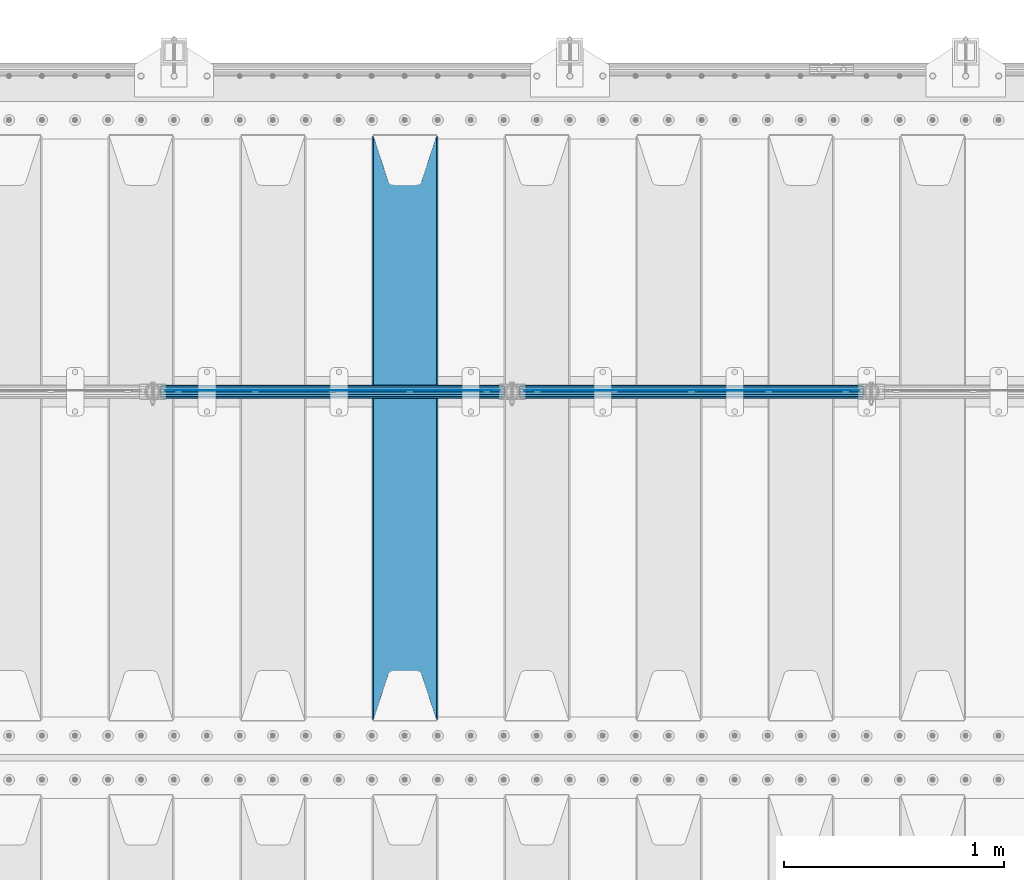
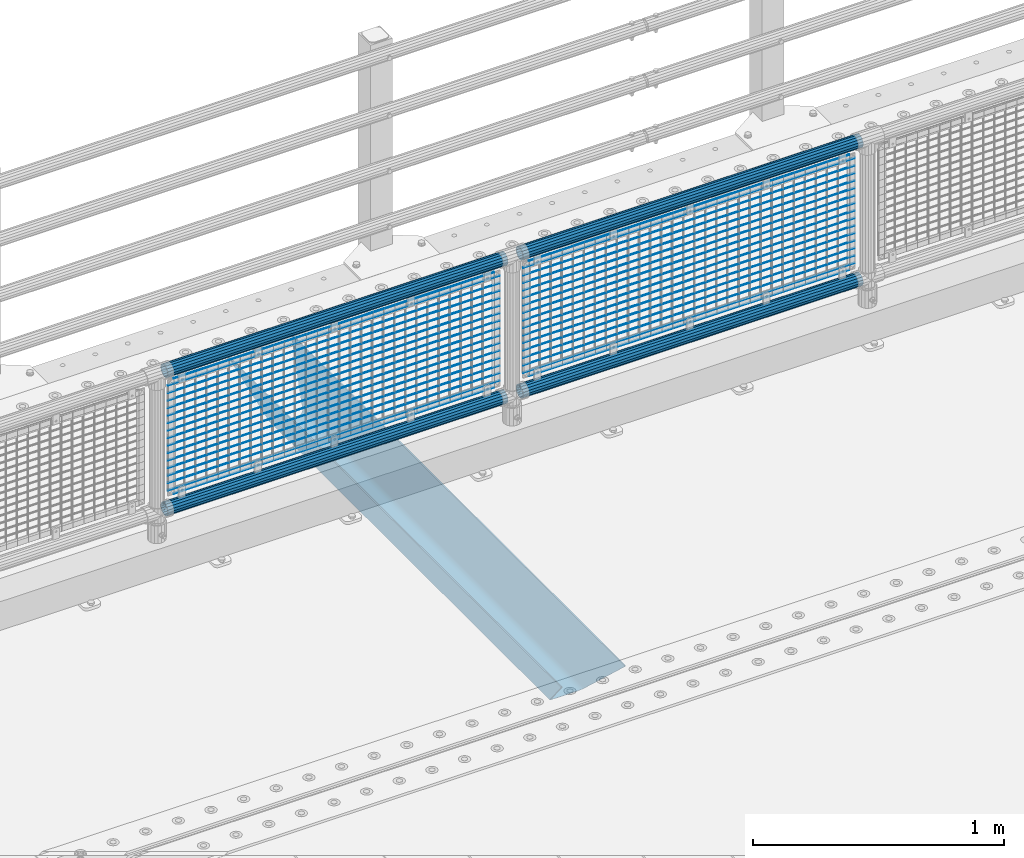
# One storey, part 115 of 242: 39 beams.
"""IFC2X3 building model written with IfcOpenShell, lengths in millimetres."""

from ifc_helpers import new_model, si_unit, frame, origin_with_axes, place, context, subcontext, project, spatial, faceted_brep, material, type_object, element, save


model = new_model("IFC2X3")

# Units and contexts
model_context = context("Model", 3, precision=1e-05, world=origin_with_axes())
body_context = subcontext(model_context, "Body", "Model", "MODEL_VIEW")
ifc_project = project(units=[si_unit("LENGTHUNIT", "METRE", prefix="MILLI"), si_unit("AREAUNIT", "SQUARE_METRE"), si_unit("VOLUMEUNIT", "CUBIC_METRE"), si_unit("MASSUNIT", "GRAM", prefix="KILO"), si_unit("TIMEUNIT", "SECOND"), si_unit("PLANEANGLEUNIT", "RADIAN"), si_unit("SOLIDANGLEUNIT", "STERADIAN"), si_unit("THERMODYNAMICTEMPERATUREUNIT", "DEGREE_CELSIUS"), si_unit("LUMINOUSINTENSITYUNIT", "LUMEN")], contexts=[model_context])

# Site, building, storey
site_placement = place(None, origin_with_axes())
site = spatial("IfcSite", under=ifc_project, at=site_placement, CompositionType="ELEMENT")
building_placement = place(site_placement, origin_with_axes())
building = spatial("IfcBuilding", under=site, at=building_placement, Name="Standard", CompositionType="ELEMENT")
storey_placement = place(building_placement, origin_with_axes())
storey = spatial("IfcBuildingStorey", under=building, at=storey_placement, Name="Undefined", CompositionType="ELEMENT", Elevation=0.0)

# Beams
ifc_material_1 = material(Name="Misc_Undefined")
beam_type_1 = type_object("IfcBeamType", Name="D3", PredefinedType="NOTDEFINED")
for number, where, z_axis, x_axis in (
    (1, (-38508.0, -19329.5, 851.596999999999), (0.0, 0.0, 1.0), (1.0, 0.0, 0.0)),
    (2, (-38508.0, -19329.5, 669.452), (0.0, 0.0, 1.0), (1.0, 0.0, 0.0)),
    (3, (-38508.0, -19329.5, 523.736), (0.0, 0.0, 1.0), (1.0, 0.0, 0.0)),
    (4, (-38508.0, -19329.5, 487.307), (0.0, 0.0, 1.0), (1.0, 0.0, 0.0)),
    (5, (-38508.0, -19329.5, 705.881), (0.0, 0.0, 1.0), (1.0, 0.0, 0.0)),
    (6, (-38508.0, -19329.5, 596.594), (0.0, 0.0, 1.0), (1.0, 0.0, 0.0)),
    (7, (-38508.0, -19329.5, 450.878), (0.0, 0.0, 1.0), (1.0, 0.0, 0.0)),
    (8, (-38508.0, -19329.5, 815.167999999999), (0.0, 0.0, 1.0), (1.0, 0.0, 0.0)),
    (9, (-38508.0, -19329.5, 888.025999999999), (0.0, 0.0, 1.0), (1.0, 0.0, 0.0)),
    (10, (-38508.0, -19329.5, 778.738999999999), (0.0, 0.0, 1.0), (1.0, 0.0, 0.0)),
    (11, (-38508.0, -19329.5, 742.309999999999), (0.0, 0.0, 1.0), (1.0, 0.0, 0.0)),
    (12, (-38508.0, -19329.5, 633.023), (0.0, 0.0, 1.0), (1.0, 0.0, 0.0)),
    (13, (-38508.0, -19329.5, 560.165), (0.0, 0.0, 1.0), (1.0, 0.0, 0.0)),
    (14, (-38508.0, -19329.5, 414.449), (0.0, 0.0, 1.0), (1.0, 0.0, 0.0)),
):
    element("IfcBeam", number, at=place(storey_placement, frame(where, z_axis=z_axis, x_axis=x_axis)), inside=storey, type_object=beam_type_1, material=ifc_material_1, ObjectType="D3", context=body_context, shape_type="Brep", body=[
        faceted_brep([(0.0, -1.50000000000364, 0.0), (-3.63797880709171e-12, -0.750000000003638, -1.29903810567669), (1523.0, -0.75, -1.29903810567669), (1523.0, -1.5, 0.0), (0.0, 0.749999999996362, -1.29903810567669), (1523.0, 0.75, -1.29903810567669), (-3.63797880709171e-12, 1.49999999999636, 0.0), (1523.0, 1.5, 0.0), (0.0, 0.749999999996362, 1.29903810567669), (1523.0, 0.75, 1.29903810567669), (-3.63797880709171e-12, -0.750000000003638, 1.29903810567669), (1523.0, -0.75, 1.29903810567669)], [[[0, 1, 2, 3]], [[1, 4, 5, 2]], [[4, 6, 7, 5]], [[6, 8, 9, 7]], [[8, 10, 11, 9]], [[10, 0, 3, 11]], [[5, 7, 9, 11, 3, 2]], [[10, 8, 6, 4, 1, 0]]]),
    ])
beam_1_placement = place(storey_placement, frame((-38483.0, -19329.5, 353.02), z_axis=(0.0, 0.0, 1.0), x_axis=(1.0, 0.0, 0.0)))
element("IfcBeam", 15, at=beam_1_placement, inside=storey, type_object=beam_type_1, material=ifc_material_1, ObjectType="D3", context=body_context, shape_type="Brep", body=[
    faceted_brep([(0.0, -1.50000000000364, 0.0), (-3.63797880709171e-12, -0.750000000003638, -1.29903810567669), (1473.0, -0.75, -1.29903810567669), (1473.0, -1.5, 0.0), (0.0, 0.749999999996362, -1.29903810567669), (1473.0, 0.75, -1.29903810567663), (-3.63797880709171e-12, 1.49999999999636, 0.0), (1473.0, 1.5, 0.0), (0.0, 0.749999999996362, 1.29903810567669), (1473.0, 0.75, 1.29903810567669), (-3.63797880709171e-12, -0.750000000003638, 1.29903810567669), (1473.0, -0.75, 1.29903810567669)], [[[0, 1, 2, 3]], [[1, 4, 5, 2]], [[4, 6, 7, 5]], [[6, 8, 9, 7]], [[8, 10, 11, 9]], [[10, 0, 3, 11]], [[5, 7, 9, 11, 3, 2]], [[10, 8, 6, 4, 1, 0]]]),
])
beam_2_placement = place(storey_placement, frame((-38508.0, -19329.5, 378.02), z_axis=(0.0, 0.0, 1.0), x_axis=(1.0, 0.0, 0.0)))
element("IfcBeam", 16, at=beam_2_placement, inside=storey, type_object=beam_type_1, material=ifc_material_1, ObjectType="D3", context=body_context, shape_type="Brep", body=[
    faceted_brep([(0.0, -1.50000000000364, 0.0), (-3.63797880709171e-12, -0.750000000003638, -1.29903810567669), (1523.0, -0.75, -1.29903810567669), (1523.0, -1.5, 0.0), (0.0, 0.749999999996362, -1.29903810567669), (1523.0, 0.75, -1.29903810567669), (-3.63797880709171e-12, 1.49999999999636, 0.0), (1523.0, 1.5, 0.0), (0.0, 0.749999999996362, 1.29903810567669), (1523.0, 0.75, 1.29903810567669), (-3.63797880709171e-12, -0.750000000003638, 1.29903810567669), (1523.0, -0.75, 1.29903810567669)], [[[0, 1, 2, 3]], [[1, 4, 5, 2]], [[4, 6, 7, 5]], [[6, 8, 9, 7]], [[8, 10, 11, 9]], [[10, 0, 3, 11]], [[5, 7, 9, 11, 3, 2]], [[10, 8, 6, 4, 1, 0]]]),
])
beam_3_placement = place(storey_placement, frame((-38483.0, -19329.5, 913.02), z_axis=(0.0, 0.0, 1.0), x_axis=(1.0, 0.0, 0.0)))
element("IfcBeam", 17, at=beam_3_placement, inside=storey, type_object=beam_type_1, material=ifc_material_1, ObjectType="D3", context=body_context, shape_type="Brep", body=[
    faceted_brep([(0.0, -1.50000000000364, 0.0), (-3.63797880709171e-12, -0.750000000003638, -1.29903810567669), (1473.0, -0.75, -1.29903810567669), (1473.0, -1.5, 0.0), (0.0, 0.749999999996362, -1.29903810567669), (1473.0, 0.75, -1.29903810567663), (-3.63797880709171e-12, 1.49999999999636, 0.0), (1473.0, 1.5, 0.0), (0.0, 0.749999999996362, 1.29903810567669), (1473.0, 0.75, 1.29903810567669), (-3.63797880709171e-12, -0.750000000003638, 1.29903810567669), (1473.0, -0.75, 1.29903810567669)], [[[0, 1, 2, 3]], [[1, 4, 5, 2]], [[4, 6, 7, 5]], [[6, 8, 9, 7]], [[8, 10, 11, 9]], [[10, 0, 3, 11]], [[5, 7, 9, 11, 3, 2]], [[10, 8, 6, 4, 1, 0]]]),
])
for number, where, z_axis, x_axis in (
    (18, (-40141.0, -19329.5, 851.596999999999), (0.0, 0.0, 1.0), (1.0, 0.0, 0.0)),
    (19, (-40141.0, -19329.5, 669.452), (0.0, 0.0, 1.0), (1.0, 0.0, 0.0)),
    (20, (-40141.0, -19329.5, 523.736), (0.0, 0.0, 1.0), (1.0, 0.0, 0.0)),
    (21, (-40141.0, -19329.5, 487.307), (0.0, 0.0, 1.0), (1.0, 0.0, 0.0)),
    (22, (-40141.0, -19329.5, 705.881), (0.0, 0.0, 1.0), (1.0, 0.0, 0.0)),
    (23, (-40141.0, -19329.5, 596.594), (0.0, 0.0, 1.0), (1.0, 0.0, 0.0)),
    (24, (-40141.0, -19329.5, 450.878), (0.0, 0.0, 1.0), (1.0, 0.0, 0.0)),
    (25, (-40141.0, -19329.5, 815.167999999999), (0.0, 0.0, 1.0), (1.0, 0.0, 0.0)),
    (26, (-40141.0, -19329.5, 888.025999999999), (0.0, 0.0, 1.0), (1.0, 0.0, 0.0)),
    (27, (-40141.0, -19329.5, 778.738999999999), (0.0, 0.0, 1.0), (1.0, 0.0, 0.0)),
    (28, (-40141.0, -19329.5, 742.309999999999), (0.0, 0.0, 1.0), (1.0, 0.0, 0.0)),
    (29, (-40141.0, -19329.5, 633.023), (0.0, 0.0, 1.0), (1.0, 0.0, 0.0)),
    (30, (-40141.0, -19329.5, 560.165), (0.0, 0.0, 1.0), (1.0, 0.0, 0.0)),
    (31, (-40141.0, -19329.5, 414.449), (0.0, 0.0, 1.0), (1.0, 0.0, 0.0)),
):
    element("IfcBeam", number, at=place(storey_placement, frame(where, z_axis=z_axis, x_axis=x_axis)), inside=storey, type_object=beam_type_1, material=ifc_material_1, ObjectType="D3", context=body_context, shape_type="Brep", body=[
        faceted_brep([(0.0, -1.50000000000364, 0.0), (-3.63797880709171e-12, -0.750000000003638, -1.29903810567669), (1523.0, -0.75, -1.29903810567669), (1523.0, -1.5, 0.0), (0.0, 0.749999999996362, -1.29903810567669), (1523.0, 0.75, -1.29903810567669), (-3.63797880709171e-12, 1.49999999999636, 0.0), (1523.0, 1.5, 0.0), (0.0, 0.749999999996362, 1.29903810567669), (1523.0, 0.75, 1.29903810567669), (-3.63797880709171e-12, -0.750000000003638, 1.29903810567669), (1523.0, -0.75, 1.29903810567669)], [[[0, 1, 2, 3]], [[1, 4, 5, 2]], [[4, 6, 7, 5]], [[6, 8, 9, 7]], [[8, 10, 11, 9]], [[10, 0, 3, 11]], [[5, 7, 9, 11, 3, 2]], [[10, 8, 6, 4, 1, 0]]]),
    ])
beam_4_placement = place(storey_placement, frame((-40116.0, -19329.5, 353.02), z_axis=(0.0, 0.0, 1.0), x_axis=(1.0, 0.0, 0.0)))
element("IfcBeam", 32, at=beam_4_placement, inside=storey, type_object=beam_type_1, material=ifc_material_1, ObjectType="D3", context=body_context, shape_type="Brep", body=[
    faceted_brep([(0.0, -1.50000000000364, 0.0), (-3.63797880709171e-12, -0.750000000003638, -1.29903810567669), (1473.0, -0.75, -1.29903810567669), (1473.0, -1.5, 0.0), (0.0, 0.749999999996362, -1.29903810567669), (1473.0, 0.75, -1.29903810567663), (-3.63797880709171e-12, 1.49999999999636, 0.0), (1473.0, 1.5, 0.0), (0.0, 0.749999999996362, 1.29903810567669), (1473.0, 0.75, 1.29903810567669), (-3.63797880709171e-12, -0.750000000003638, 1.29903810567669), (1473.0, -0.75, 1.29903810567669)], [[[0, 1, 2, 3]], [[1, 4, 5, 2]], [[4, 6, 7, 5]], [[6, 8, 9, 7]], [[8, 10, 11, 9]], [[10, 0, 3, 11]], [[5, 7, 9, 11, 3, 2]], [[10, 8, 6, 4, 1, 0]]]),
])
beam_5_placement = place(storey_placement, frame((-40141.0, -19329.5, 378.02), z_axis=(0.0, 0.0, 1.0), x_axis=(1.0, 0.0, 0.0)))
element("IfcBeam", 33, at=beam_5_placement, inside=storey, type_object=beam_type_1, material=ifc_material_1, ObjectType="D3", context=body_context, shape_type="Brep", body=[
    faceted_brep([(0.0, -1.50000000000364, 0.0), (-3.63797880709171e-12, -0.750000000003638, -1.29903810567669), (1523.0, -0.75, -1.29903810567669), (1523.0, -1.5, 0.0), (0.0, 0.749999999996362, -1.29903810567669), (1523.0, 0.75, -1.29903810567669), (-3.63797880709171e-12, 1.49999999999636, 0.0), (1523.0, 1.5, 0.0), (0.0, 0.749999999996362, 1.29903810567669), (1523.0, 0.75, 1.29903810567669), (-3.63797880709171e-12, -0.750000000003638, 1.29903810567669), (1523.0, -0.75, 1.29903810567669)], [[[0, 1, 2, 3]], [[1, 4, 5, 2]], [[4, 6, 7, 5]], [[6, 8, 9, 7]], [[8, 10, 11, 9]], [[10, 0, 3, 11]], [[5, 7, 9, 11, 3, 2]], [[10, 8, 6, 4, 1, 0]]]),
])
beam_6_placement = place(storey_placement, frame((-40116.0, -19329.5, 913.02), z_axis=(0.0, 0.0, 1.0), x_axis=(1.0, 0.0, 0.0)))
element("IfcBeam", 34, at=beam_6_placement, inside=storey, type_object=beam_type_1, material=ifc_material_1, ObjectType="D3", context=body_context, shape_type="Brep", body=[
    faceted_brep([(0.0, -1.50000000000364, 0.0), (-3.63797880709171e-12, -0.750000000003638, -1.29903810567669), (1473.0, -0.75, -1.29903810567669), (1473.0, -1.5, 0.0), (0.0, 0.749999999996362, -1.29903810567669), (1473.0, 0.75, -1.29903810567663), (-3.63797880709171e-12, 1.49999999999636, 0.0), (1473.0, 1.5, 0.0), (0.0, 0.749999999996362, 1.29903810567669), (1473.0, 0.75, 1.29903810567669), (-3.63797880709171e-12, -0.750000000003638, 1.29903810567669), (1473.0, -0.75, 1.29903810567669)], [[[0, 1, 2, 3]], [[1, 4, 5, 2]], [[4, 6, 7, 5]], [[6, 8, 9, 7]], [[8, 10, 11, 9]], [[10, 0, 3, 11]], [[5, 7, 9, 11, 3, 2]], [[10, 8, 6, 4, 1, 0]]]),
])
ifc_material_2 = material()
beam_type_2 = type_object("IfcBeamType", PredefinedType="NOTDEFINED")
beam_7_placement = place(storey_placement, frame((-38528.15, -19335.5, 969.849999999999), z_axis=(0.0, 0.0, 1.0), x_axis=(1.0, 0.0, 0.0)))
element("IfcBeam", 35, at=beam_7_placement, inside=storey, type_object=beam_type_2, material=ifc_material_2, context=body_context, shape_type="Brep", body=[
    faceted_brep([(0.0, -25.3499999999985, 0.0), (0.0, -23.4203461491597, 9.70102501045403), (1563.0, -23.4203461491597, 9.70102501045506), (1563.0, -25.3499999999985, 0.0), (0.0, -17.9251569030785, 17.9251569030785), (1563.0, -17.9251569030785, 17.925156903079), (0.0, -9.70102501045403, 23.4203461491597), (1563.0, -9.70102501045403, 23.4203461491611), (0.0, 0.0, 25.3499999999985), (1563.0, 0.0, 25.35), (0.0, 9.70102501045403, 23.4203461491597), (1563.0, 9.70102501045403, 23.4203461491611), (0.0, 17.9251569030785, 17.9251569030785), (1563.0, 17.9251569030785, 17.925156903079), (0.0, 23.4203461491597, 9.70102501045403), (1563.0, 23.4203461491597, 9.70102501045506), (0.0, 25.3499999999985, 0.0), (1563.0, 25.3499999999985, 0.0), (0.0, 23.4203461491597, -9.70102501045403), (1563.0, 23.4203461491597, -9.70102501045506), (0.0, 17.9251569030785, -17.9251569030785), (1563.0, 17.9251569030785, -17.925156903079), (0.0, 9.70102501045403, -23.4203461491597), (1563.0, 9.70102501045403, -23.4203461491611), (0.0, 0.0, -25.3499999999985), (1563.0, 0.0, -25.35), (0.0, -9.70102501045403, -23.4203461491597), (1563.0, -9.70102501045403, -23.4203461491611), (0.0, -17.9251569030785, -17.9251569030785), (1563.0, -17.9251569030785, -17.925156903079), (0.0, -23.4203461491597, -9.70102501045403), (1563.0, -23.4203461491597, -9.70102501045506), (0.0, -30.1500000000015, 0.0), (0.0, -27.8549679052157, -11.5379054858058), (1563.0, -27.8549679052157, -11.5379054858075), (1563.0, -30.1500000000015, 0.0), (0.0, -21.3192694527752, -21.3192694527752), (1563.0, -21.3192694527752, -21.3192694527744), (0.0, -11.5379054858058, -27.8549679052157), (1563.0, -11.5379054858058, -27.8549679052153), (0.0, 0.0, -30.1500000000015), (1563.0, 0.0, -30.15), (0.0, 11.5379054858058, -27.8549679052157), (1563.0, 11.5379054858058, -27.8549679052153), (0.0, 21.3192694527752, -21.3192694527752), (1563.0, 21.3192694527752, -21.3192694527744), (0.0, 27.8549679052157, -11.5379054858058), (1563.0, 27.8549679052157, -11.5379054858074), (0.0, 30.1500000000015, 0.0), (1563.0, 30.1500000000015, 0.0), (0.0, 27.8549679052157, 11.5379054858058), (1563.0, 27.8549679052157, 11.5379054858074), (0.0, 21.3192694527752, 21.3192694527752), (1563.0, 21.3192694527752, 21.3192694527744), (0.0, 11.5379054858058, 27.8549679052157), (1563.0, 11.5379054858058, 27.8549679052153), (0.0, 0.0, 30.1500000000015), (1563.0, 0.0, 30.15), (0.0, -11.5379054858058, 27.8549679052157), (1563.0, -11.5379054858058, 27.8549679052153), (0.0, -21.3192694527752, 21.3192694527752), (1563.0, -21.3192694527752, 21.3192694527744), (0.0, -27.8549679052157, 11.5379054858058), (1563.0, -27.8549679052157, 11.5379054858074)], [[[0, 1, 2, 3]], [[1, 4, 5, 2]], [[4, 6, 7, 5]], [[6, 8, 9, 7]], [[8, 10, 11, 9]], [[10, 12, 13, 11]], [[12, 14, 15, 13]], [[14, 16, 17, 15]], [[16, 18, 19, 17]], [[18, 20, 21, 19]], [[20, 22, 23, 21]], [[22, 24, 25, 23]], [[24, 26, 27, 25]], [[26, 28, 29, 27]], [[28, 30, 31, 29]], [[30, 0, 3, 31]], [[32, 33, 34, 35]], [[33, 36, 37, 34]], [[36, 38, 39, 37]], [[38, 40, 41, 39]], [[40, 42, 43, 41]], [[42, 44, 45, 43]], [[44, 46, 47, 45]], [[46, 48, 49, 47]], [[48, 50, 51, 49]], [[50, 52, 53, 51]], [[52, 54, 55, 53]], [[54, 56, 57, 55]], [[56, 58, 59, 57]], [[58, 60, 61, 59]], [[60, 62, 63, 61]], [[62, 32, 35, 63]], [[37, 39, 41, 43, 45, 47, 49, 51, 53, 55, 57, 59, 61, 63, 35, 34], [5, 7, 9, 11, 13, 15, 17, 19, 21, 23, 25, 27, 29, 31, 3, 2]], [[62, 60, 58, 56, 54, 52, 50, 48, 46, 44, 42, 40, 38, 36, 33, 32], [30, 28, 26, 24, 22, 20, 18, 16, 14, 12, 10, 8, 6, 4, 1, 0]]]),
])
beam_8_placement = place(storey_placement, frame((-38528.15, -19335.5, 298.170000000001), z_axis=(0.0, 0.0, 1.0), x_axis=(1.0, 0.0, 0.0)))
element("IfcBeam", 36, at=beam_8_placement, inside=storey, type_object=beam_type_2, material=ifc_material_2, context=body_context, shape_type="Brep", body=[
    faceted_brep([(0.0, -25.3499999999985, 0.0), (0.0, -23.4203461491597, 9.70102501045403), (1563.0, -23.4203461491597, 9.70102501045506), (1563.0, -25.3499999999985, 0.0), (0.0, -17.9251569030785, 17.9251569030785), (1563.0, -17.9251569030785, 17.925156903079), (0.0, -9.70102501045403, 23.4203461491597), (1563.0, -9.70102501045403, 23.4203461491611), (0.0, 0.0, 25.3499999999985), (1563.0, 0.0, 25.35), (0.0, 9.70102501045403, 23.4203461491597), (1563.0, 9.70102501045403, 23.4203461491611), (0.0, 17.9251569030785, 17.9251569030785), (1563.0, 17.9251569030785, 17.925156903079), (0.0, 23.4203461491597, 9.70102501045403), (1563.0, 23.4203461491597, 9.70102501045506), (0.0, 25.3499999999985, 0.0), (1563.0, 25.3499999999985, 0.0), (0.0, 23.4203461491597, -9.70102501045403), (1563.0, 23.4203461491597, -9.70102501045506), (0.0, 17.9251569030785, -17.9251569030785), (1563.0, 17.9251569030785, -17.925156903079), (0.0, 9.70102501045403, -23.4203461491597), (1563.0, 9.70102501045403, -23.4203461491611), (0.0, 0.0, -25.3499999999985), (1563.0, 0.0, -25.35), (0.0, -9.70102501045403, -23.4203461491597), (1563.0, -9.70102501045403, -23.4203461491611), (0.0, -17.9251569030785, -17.9251569030785), (1563.0, -17.9251569030785, -17.925156903079), (0.0, -23.4203461491597, -9.70102501045403), (1563.0, -23.4203461491597, -9.70102501045506), (0.0, -30.1500000000015, 0.0), (0.0, -27.8549679052157, -11.5379054858058), (1563.0, -27.8549679052157, -11.5379054858075), (1563.0, -30.1500000000015, 0.0), (0.0, -21.3192694527752, -21.3192694527752), (1563.0, -21.3192694527752, -21.3192694527744), (0.0, -11.5379054858058, -27.8549679052157), (1563.0, -11.5379054858058, -27.8549679052153), (0.0, 0.0, -30.1500000000015), (1563.0, 0.0, -30.15), (0.0, 11.5379054858058, -27.8549679052157), (1563.0, 11.5379054858058, -27.8549679052153), (0.0, 21.3192694527752, -21.3192694527752), (1563.0, 21.3192694527752, -21.3192694527744), (0.0, 27.8549679052157, -11.5379054858058), (1563.0, 27.8549679052157, -11.5379054858074), (0.0, 30.1500000000015, 0.0), (1563.0, 30.1500000000015, 0.0), (0.0, 27.8549679052157, 11.5379054858058), (1563.0, 27.8549679052157, 11.5379054858074), (0.0, 21.3192694527752, 21.3192694527752), (1563.0, 21.3192694527752, 21.3192694527744), (0.0, 11.5379054858058, 27.8549679052157), (1563.0, 11.5379054858058, 27.8549679052153), (0.0, 0.0, 30.1500000000015), (1563.0, 0.0, 30.15), (0.0, -11.5379054858058, 27.8549679052157), (1563.0, -11.5379054858058, 27.8549679052153), (0.0, -21.3192694527752, 21.3192694527752), (1563.0, -21.3192694527752, 21.3192694527744), (0.0, -27.8549679052157, 11.5379054858058), (1563.0, -27.8549679052157, 11.5379054858074)], [[[0, 1, 2, 3]], [[1, 4, 5, 2]], [[4, 6, 7, 5]], [[6, 8, 9, 7]], [[8, 10, 11, 9]], [[10, 12, 13, 11]], [[12, 14, 15, 13]], [[14, 16, 17, 15]], [[16, 18, 19, 17]], [[18, 20, 21, 19]], [[20, 22, 23, 21]], [[22, 24, 25, 23]], [[24, 26, 27, 25]], [[26, 28, 29, 27]], [[28, 30, 31, 29]], [[30, 0, 3, 31]], [[32, 33, 34, 35]], [[33, 36, 37, 34]], [[36, 38, 39, 37]], [[38, 40, 41, 39]], [[40, 42, 43, 41]], [[42, 44, 45, 43]], [[44, 46, 47, 45]], [[46, 48, 49, 47]], [[48, 50, 51, 49]], [[50, 52, 53, 51]], [[52, 54, 55, 53]], [[54, 56, 57, 55]], [[56, 58, 59, 57]], [[58, 60, 61, 59]], [[60, 62, 63, 61]], [[62, 32, 35, 63]], [[37, 39, 41, 43, 45, 47, 49, 51, 53, 55, 57, 59, 61, 63, 35, 34], [5, 7, 9, 11, 13, 15, 17, 19, 21, 23, 25, 27, 29, 31, 3, 2]], [[62, 60, 58, 56, 54, 52, 50, 48, 46, 44, 42, 40, 38, 36, 33, 32], [30, 28, 26, 24, 22, 20, 18, 16, 14, 12, 10, 8, 6, 4, 1, 0]]]),
])
beam_9_placement = place(storey_placement, frame((-40161.15, -19335.5, 969.849999999999), z_axis=(0.0, 0.0, 1.0), x_axis=(1.0, 0.0, 0.0)))
element("IfcBeam", 37, at=beam_9_placement, inside=storey, type_object=beam_type_2, material=ifc_material_2, context=body_context, shape_type="Brep", body=[
    faceted_brep([(0.0, -25.3499999999985, 0.0), (0.0, -23.4203461491597, 9.70102501045403), (1563.0, -23.4203461491597, 9.70102501045506), (1563.0, -25.3499999999985, 0.0), (0.0, -17.9251569030785, 17.9251569030785), (1563.0, -17.9251569030785, 17.925156903079), (0.0, -9.70102501045403, 23.4203461491597), (1563.0, -9.70102501045403, 23.4203461491611), (0.0, 0.0, 25.3499999999985), (1563.0, 0.0, 25.35), (0.0, 9.70102501045403, 23.4203461491597), (1563.0, 9.70102501045403, 23.4203461491611), (0.0, 17.9251569030785, 17.9251569030785), (1563.0, 17.9251569030785, 17.925156903079), (0.0, 23.4203461491597, 9.70102501045403), (1563.0, 23.4203461491597, 9.70102501045506), (0.0, 25.3499999999985, 0.0), (1563.0, 25.3499999999985, 0.0), (0.0, 23.4203461491597, -9.70102501045403), (1563.0, 23.4203461491597, -9.70102501045506), (0.0, 17.9251569030785, -17.9251569030785), (1563.0, 17.9251569030785, -17.925156903079), (0.0, 9.70102501045403, -23.4203461491597), (1563.0, 9.70102501045403, -23.4203461491611), (0.0, 0.0, -25.3499999999985), (1563.0, 0.0, -25.35), (0.0, -9.70102501045403, -23.4203461491597), (1563.0, -9.70102501045403, -23.4203461491611), (0.0, -17.9251569030785, -17.9251569030785), (1563.0, -17.9251569030785, -17.925156903079), (0.0, -23.4203461491597, -9.70102501045403), (1563.0, -23.4203461491597, -9.70102501045506), (0.0, -30.1500000000015, 0.0), (0.0, -27.8549679052157, -11.5379054858058), (1563.0, -27.8549679052157, -11.5379054858075), (1563.0, -30.1500000000015, 0.0), (0.0, -21.3192694527752, -21.3192694527752), (1563.0, -21.3192694527752, -21.3192694527744), (0.0, -11.5379054858058, -27.8549679052157), (1563.0, -11.5379054858058, -27.8549679052153), (0.0, 0.0, -30.1500000000015), (1563.0, 0.0, -30.15), (0.0, 11.5379054858058, -27.8549679052157), (1563.0, 11.5379054858058, -27.8549679052153), (0.0, 21.3192694527752, -21.3192694527752), (1563.0, 21.3192694527752, -21.3192694527744), (0.0, 27.8549679052157, -11.5379054858058), (1563.0, 27.8549679052157, -11.5379054858074), (0.0, 30.1500000000015, 0.0), (1563.0, 30.1500000000015, 0.0), (0.0, 27.8549679052157, 11.5379054858058), (1563.0, 27.8549679052157, 11.5379054858074), (0.0, 21.3192694527752, 21.3192694527752), (1563.0, 21.3192694527752, 21.3192694527744), (0.0, 11.5379054858058, 27.8549679052157), (1563.0, 11.5379054858058, 27.8549679052153), (0.0, 0.0, 30.1500000000015), (1563.0, 0.0, 30.15), (0.0, -11.5379054858058, 27.8549679052157), (1563.0, -11.5379054858058, 27.8549679052153), (0.0, -21.3192694527752, 21.3192694527752), (1563.0, -21.3192694527752, 21.3192694527744), (0.0, -27.8549679052157, 11.5379054858058), (1563.0, -27.8549679052157, 11.5379054858074)], [[[0, 1, 2, 3]], [[1, 4, 5, 2]], [[4, 6, 7, 5]], [[6, 8, 9, 7]], [[8, 10, 11, 9]], [[10, 12, 13, 11]], [[12, 14, 15, 13]], [[14, 16, 17, 15]], [[16, 18, 19, 17]], [[18, 20, 21, 19]], [[20, 22, 23, 21]], [[22, 24, 25, 23]], [[24, 26, 27, 25]], [[26, 28, 29, 27]], [[28, 30, 31, 29]], [[30, 0, 3, 31]], [[32, 33, 34, 35]], [[33, 36, 37, 34]], [[36, 38, 39, 37]], [[38, 40, 41, 39]], [[40, 42, 43, 41]], [[42, 44, 45, 43]], [[44, 46, 47, 45]], [[46, 48, 49, 47]], [[48, 50, 51, 49]], [[50, 52, 53, 51]], [[52, 54, 55, 53]], [[54, 56, 57, 55]], [[56, 58, 59, 57]], [[58, 60, 61, 59]], [[60, 62, 63, 61]], [[62, 32, 35, 63]], [[37, 39, 41, 43, 45, 47, 49, 51, 53, 55, 57, 59, 61, 63, 35, 34], [5, 7, 9, 11, 13, 15, 17, 19, 21, 23, 25, 27, 29, 31, 3, 2]], [[62, 60, 58, 56, 54, 52, 50, 48, 46, 44, 42, 40, 38, 36, 33, 32], [30, 28, 26, 24, 22, 20, 18, 16, 14, 12, 10, 8, 6, 4, 1, 0]]]),
])
beam_10_placement = place(storey_placement, frame((-40161.15, -19335.5, 298.170000000001), z_axis=(0.0, 0.0, 1.0), x_axis=(1.0, 0.0, 0.0)))
element("IfcBeam", 38, at=beam_10_placement, inside=storey, type_object=beam_type_2, material=ifc_material_2, context=body_context, shape_type="Brep", body=[
    faceted_brep([(0.0, -25.3499999999985, 0.0), (0.0, -23.4203461491597, 9.70102501045403), (1563.0, -23.4203461491597, 9.70102501045506), (1563.0, -25.3499999999985, 0.0), (0.0, -17.9251569030785, 17.9251569030785), (1563.0, -17.9251569030785, 17.925156903079), (0.0, -9.70102501045403, 23.4203461491597), (1563.0, -9.70102501045403, 23.4203461491611), (0.0, 0.0, 25.3499999999985), (1563.0, 0.0, 25.35), (0.0, 9.70102501045403, 23.4203461491597), (1563.0, 9.70102501045403, 23.4203461491611), (0.0, 17.9251569030785, 17.9251569030785), (1563.0, 17.9251569030785, 17.925156903079), (0.0, 23.4203461491597, 9.70102501045403), (1563.0, 23.4203461491597, 9.70102501045506), (0.0, 25.3499999999985, 0.0), (1563.0, 25.3499999999985, 0.0), (0.0, 23.4203461491597, -9.70102501045403), (1563.0, 23.4203461491597, -9.70102501045506), (0.0, 17.9251569030785, -17.9251569030785), (1563.0, 17.9251569030785, -17.925156903079), (0.0, 9.70102501045403, -23.4203461491597), (1563.0, 9.70102501045403, -23.4203461491611), (0.0, 0.0, -25.3499999999985), (1563.0, 0.0, -25.35), (0.0, -9.70102501045403, -23.4203461491597), (1563.0, -9.70102501045403, -23.4203461491611), (0.0, -17.9251569030785, -17.9251569030785), (1563.0, -17.9251569030785, -17.925156903079), (0.0, -23.4203461491597, -9.70102501045403), (1563.0, -23.4203461491597, -9.70102501045506), (0.0, -30.1500000000015, 0.0), (0.0, -27.8549679052157, -11.5379054858058), (1563.0, -27.8549679052157, -11.5379054858075), (1563.0, -30.1500000000015, 0.0), (0.0, -21.3192694527752, -21.3192694527752), (1563.0, -21.3192694527752, -21.3192694527744), (0.0, -11.5379054858058, -27.8549679052157), (1563.0, -11.5379054858058, -27.8549679052153), (0.0, 0.0, -30.1500000000015), (1563.0, 0.0, -30.15), (0.0, 11.5379054858058, -27.8549679052157), (1563.0, 11.5379054858058, -27.8549679052153), (0.0, 21.3192694527752, -21.3192694527752), (1563.0, 21.3192694527752, -21.3192694527744), (0.0, 27.8549679052157, -11.5379054858058), (1563.0, 27.8549679052157, -11.5379054858074), (0.0, 30.1500000000015, 0.0), (1563.0, 30.1500000000015, 0.0), (0.0, 27.8549679052157, 11.5379054858058), (1563.0, 27.8549679052157, 11.5379054858074), (0.0, 21.3192694527752, 21.3192694527752), (1563.0, 21.3192694527752, 21.3192694527744), (0.0, 11.5379054858058, 27.8549679052157), (1563.0, 11.5379054858058, 27.8549679052153), (0.0, 0.0, 30.1500000000015), (1563.0, 0.0, 30.15), (0.0, -11.5379054858058, 27.8549679052157), (1563.0, -11.5379054858058, 27.8549679052153), (0.0, -21.3192694527752, 21.3192694527752), (1563.0, -21.3192694527752, 21.3192694527744), (0.0, -27.8549679052157, 11.5379054858058), (1563.0, -27.8549679052157, 11.5379054858074)], [[[0, 1, 2, 3]], [[1, 4, 5, 2]], [[4, 6, 7, 5]], [[6, 8, 9, 7]], [[8, 10, 11, 9]], [[10, 12, 13, 11]], [[12, 14, 15, 13]], [[14, 16, 17, 15]], [[16, 18, 19, 17]], [[18, 20, 21, 19]], [[20, 22, 23, 21]], [[22, 24, 25, 23]], [[24, 26, 27, 25]], [[26, 28, 29, 27]], [[28, 30, 31, 29]], [[30, 0, 3, 31]], [[32, 33, 34, 35]], [[33, 36, 37, 34]], [[36, 38, 39, 37]], [[38, 40, 41, 39]], [[40, 42, 43, 41]], [[42, 44, 45, 43]], [[44, 46, 47, 45]], [[46, 48, 49, 47]], [[48, 50, 51, 49]], [[50, 52, 53, 51]], [[52, 54, 55, 53]], [[54, 56, 57, 55]], [[56, 58, 59, 57]], [[58, 60, 61, 59]], [[60, 62, 63, 61]], [[62, 32, 35, 63]], [[37, 39, 41, 43, 45, 47, 49, 51, 53, 55, 57, 59, 61, 63, 35, 34], [5, 7, 9, 11, 13, 15, 17, 19, 21, 23, 25, 27, 29, 31, 3, 2]], [[62, 60, 58, 56, 54, 52, 50, 48, 46, 44, 42, 40, 38, 36, 33, 32], [30, 28, 26, 24, 22, 20, 18, 16, 14, 12, 10, 8, 6, 4, 1, 0]]]),
])
ifc_material_3 = material(Name="STEEL/S355N")
beam_type_3 = type_object("IfcBeamType", PredefinedType="NOTDEFINED")
beam_11_placement = place(storey_placement, frame((-39050.0, -20825.0, -115.0), z_axis=(0.0, 0.0, 1.0), x_axis=(0.0, 1.0, 0.0)))
element("IfcBeam", 39, at=beam_11_placement, inside=storey, type_object=beam_type_3, material=ifc_material_3, context=body_context, shape_type="Brep", body=[
    faceted_brep([(0.0, 150.0, 115.0), (0.0, 143.689999999999, 115.0), (2650.00000000297, 143.689999999999, 115.0), (2650.00000000297, 150.0, 115.0), (2650.00000000297, 142.059565218402, 110.000000003099), (2650.00000000297, 148.369565218403, 110.000000003099), (2441.90079219209, -80.1103600731112, -98.0992078077845), (2437.7588105432, -77.5672621345584, -102.241189456673), (2434.06523489747, -74.4080125315522, -105.934765102404), (2430.91086095089, -70.710272125576, -109.089139048974), (2428.37322971128, -66.5649389910068, -111.626770288588), (2426.51472138055, -62.0739139532889, -113.485278619323), (2425.38102192092, -57.3475956567672, -114.618978078955), (2424.99999999987, -52.5021667386536, -115.0), (2424.99999999987, 52.5021667386536, -115.0), (2425.38102192092, 57.3475956567672, -114.618978078955), (2426.51472138055, 62.0739139532889, -113.485278619323), (2428.37322971128, 66.5649389910068, -111.626770288588), (2430.91086095089, 70.710272125576, -109.089139048974), (2434.06523489747, 74.4080125315522, -105.934765102404), (2437.7588105432, 77.5672621345584, -102.241189456673), (2441.90079219209, 80.1103600731112, -98.0992078077846), (2446.38936140511, 81.9747917625791, -93.6106385947584), (2448.2494850041, 76.2713538057251, -91.7505149957729), (2444.62967112262, 74.76777986261, -95.3703288772456), (2441.28936334126, 72.7168944282894, -98.710636658607), (2438.31067330438, 70.1691124903846, -101.689326695487), (2435.76682334747, 67.1870637758839, -104.233176652398), (2433.72034654133, 63.8440531834895, -106.279653458539), (2432.22154950042, 60.222258798236, -107.778450499454), (2431.30727574265, 56.4107117849089, -108.692724257221), (2430.99999999987, 52.5031078186876, -109.0), (2430.99999999987, -52.5031078186876, -109.0), (2431.30727574265, -56.4107117849089, -108.692724257221), (2432.22154950042, -60.222258798236, -107.778450499454), (2433.72034654133, -63.8440531834895, -106.279653458539), (2435.76682334747, -67.1870637758839, -104.233176652398), (2438.31067330438, -70.1691124903846, -101.689326695487), (2441.28936334126, -72.7168944282894, -98.7106366586071), (2444.62967112262, -74.76777986261, -95.3703288772457), (2448.2494850041, -76.2713538057251, -91.7505149957729), (2650.00000000297, -142.059565218402, 110.000000003099), (2650.00000000297, -148.369565218403, 110.000000003099), (2446.38936140511, -81.9747917625791, -93.6106385947584), (2650.00000000297, -143.689999999999, 115.0), (2650.00000000297, -150.0, 115.0), (0.0, -143.689999999999, 115.0), (0.0, -150.0, 115.0), (0.0, -148.369565218261, 110.000000002669), (203.610638597427, -81.9747917625791, -93.6106385947584), (208.099207810454, -80.1103600731112, -98.0992078077845), (212.241189459342, -77.5672621345584, -102.241189456673), (215.934765105074, -74.4080125315522, -105.934765102404), (219.089139051644, -70.710272125576, -109.089139048974), (221.626770291256, -66.5649389910068, -111.626770288588), (223.485278621993, -62.0739139532889, -113.485278619323), (224.618978081624, -57.3475956567672, -114.618978078955), (225.00000000267, -52.5021667386536, -115.0), (225.00000000267, 52.5021667386536, -115.0), (224.618978081624, 57.3475956567672, -114.618978078955), (223.485278621993, 62.0739139532889, -113.485278619323), (221.626770291256, 66.5649389910068, -111.626770288588), (219.089139051644, 70.710272125576, -109.089139048974), (215.934765105074, 74.4080125315522, -105.934765102404), (212.241189459342, 77.5672621345584, -102.241189456673), (208.099207810454, 80.1103600731112, -98.0992078077846), (203.610638597427, 81.9747917625791, -93.6106385947584), (0.0, 148.369565218261, 110.000000002669), (0.0, 142.05956521826, 110.000000002669), (201.750514998443, 76.2713538057251, -91.7505149957729), (205.370328879915, 74.76777986261, -95.3703288772456), (208.710636661275, 72.7168944282894, -98.710636658607), (211.689326698157, 70.1691124903846, -101.689326695487), (214.233176655067, 67.1870637758839, -104.233176652398), (216.279653461206, 63.8440531834895, -106.279653458539), (217.778450502123, 60.222258798236, -107.778450499454), (218.69272425989, 56.4107117849089, -108.692724257221), (219.00000000267, 52.5031078186876, -109.0), (219.00000000267, -52.5031078186876, -109.0), (218.69272425989, -56.4107117849089, -108.692724257221), (217.778450502123, -60.222258798236, -107.778450499454), (216.279653461206, -63.8440531834895, -106.279653458539), (214.233176655067, -67.1870637758839, -104.233176652398), (211.689326698157, -70.1691124903846, -101.689326695487), (208.710636661275, -72.7168944282894, -98.7106366586071), (205.370328879915, -74.76777986261, -95.3703288772457), (201.750514998443, -76.2713538057251, -91.7505149957729), (0.0, -142.05956521826, 110.000000002669)], [[[0, 1, 2, 3]], [[3, 2, 4, 5]], [[6, 7, 8, 9, 10, 11, 12, 13, 14, 15, 16, 17, 18, 19, 20, 21, 22, 5, 4, 23, 24, 25, 26, 27, 28, 29, 30, 31, 32, 33, 34, 35, 36, 37, 38, 39, 40, 41, 42, 43]], [[44, 45, 42, 41]], [[46, 47, 45, 44]], [[43, 42, 45, 47, 48, 49]], [[6, 43, 49, 50]], [[7, 6, 50, 51]], [[8, 7, 51, 52]], [[9, 8, 52, 53]], [[10, 9, 53, 54]], [[11, 10, 54, 55]], [[12, 11, 55, 56]], [[13, 12, 56, 57]], [[14, 13, 57, 58]], [[15, 14, 58, 59]], [[16, 15, 59, 60]], [[17, 16, 60, 61]], [[18, 17, 61, 62]], [[19, 18, 62, 63]], [[20, 19, 63, 64]], [[21, 20, 64, 65]], [[22, 21, 65, 66]], [[0, 3, 5, 22, 66, 67]], [[1, 0, 67, 68]], [[23, 4, 2, 1, 68, 69]], [[24, 23, 69, 70]], [[25, 24, 70, 71]], [[26, 25, 71, 72]], [[27, 26, 72, 73]], [[28, 27, 73, 74]], [[29, 28, 74, 75]], [[30, 29, 75, 76]], [[31, 30, 76, 77]], [[32, 31, 77, 78]], [[33, 32, 78, 79]], [[34, 33, 79, 80]], [[35, 34, 80, 81]], [[36, 35, 81, 82]], [[37, 36, 82, 83]], [[38, 37, 83, 84]], [[39, 38, 84, 85]], [[40, 39, 85, 86]], [[46, 44, 41, 40, 86, 87]], [[47, 46, 87, 48]], [[86, 85, 84, 83, 82, 81, 80, 79, 78, 77, 76, 75, 74, 73, 72, 71, 70, 69, 68, 67, 66, 65, 64, 63, 62, 61, 60, 59, 58, 57, 56, 55, 54, 53, 52, 51, 50, 49, 48, 87]]]),
])

save(model, "model.ifc")
